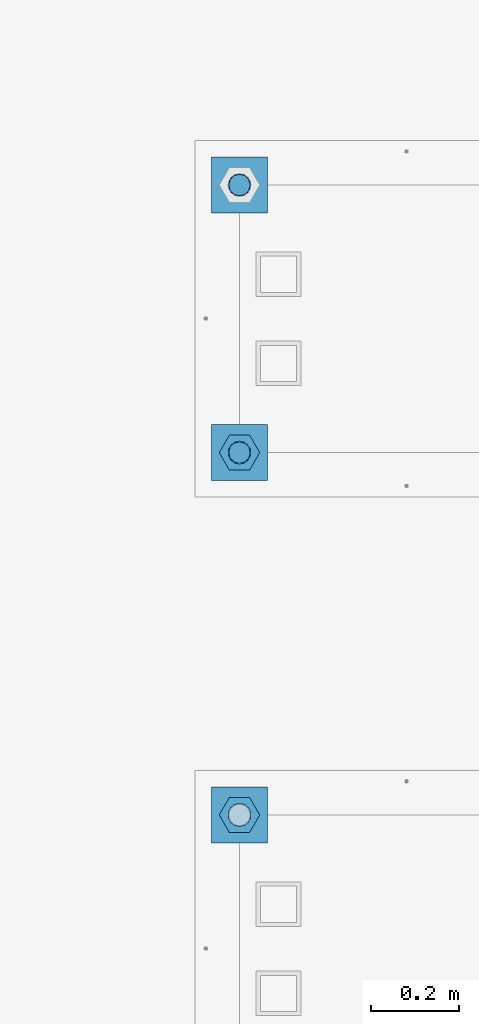
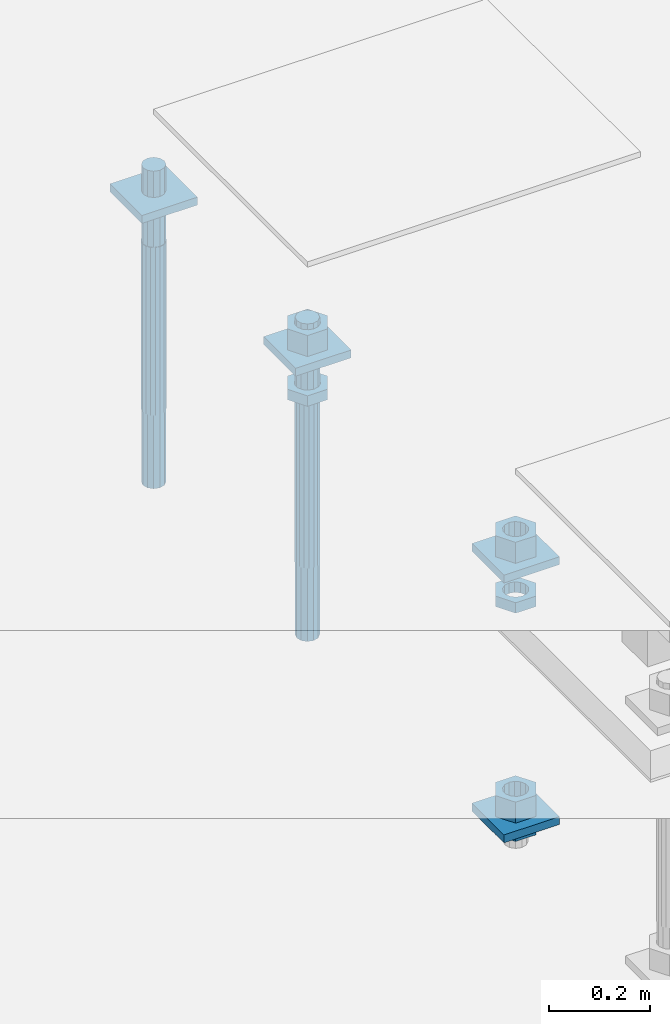
# One storey, part 2559 of 3843: 12 beams, 2 elements without a shape of their own.
"""IFC2X3 building model written with IfcOpenShell, lengths in millimetres."""

from ifc_helpers import new_model, si_unit, frame, origin_with_axes, place, context, subcontext, project, spatial, faceted_brep, material, type_object, element, aggregate, save


model = new_model("IFC2X3")

# Units and contexts
model_context = context("Model", 3, precision=1e-05, world=origin_with_axes())
body_context = subcontext(model_context, "Body", "Model", "MODEL_VIEW")
ifc_project = project(units=[si_unit("LENGTHUNIT", "METRE", prefix="MILLI"), si_unit("AREAUNIT", "SQUARE_METRE"), si_unit("VOLUMEUNIT", "CUBIC_METRE"), si_unit("MASSUNIT", "GRAM", prefix="KILO"), si_unit("TIMEUNIT", "SECOND"), si_unit("PLANEANGLEUNIT", "RADIAN"), si_unit("SOLIDANGLEUNIT", "STERADIAN"), si_unit("THERMODYNAMICTEMPERATUREUNIT", "DEGREE_CELSIUS"), si_unit("LUMINOUSINTENSITYUNIT", "LUMEN")], contexts=[model_context])

# Site, building, storey
site_placement = place(None, origin_with_axes())
site = spatial("IfcSite", under=ifc_project, at=site_placement, CompositionType="ELEMENT")
building_placement = place(site_placement, origin_with_axes())
building = spatial("IfcBuilding", under=site, at=building_placement, Name="Undefined", CompositionType="ELEMENT")
storey_placement = place(building_placement, origin_with_axes())
storey = spatial("IfcBuildingStorey", under=building, at=storey_placement, Name="Undefined", CompositionType="ELEMENT", Elevation=0.0)

# Assembly, beams
assembly_1_placement = place(storey_placement, origin_with_axes())
assembly_1 = element("IfcElementAssembly", 1, at=assembly_1_placement, inside=storey, Name="TEMPLATE", AssemblyPlace="NOTDEFINED", PredefinedType="RIGID_FRAME")
ifc_material_1 = material(Name="STEEL/A572-50")
beam_type_1 = type_object("IfcBeamType", PredefinedType="NOTDEFINED")
beam_1_placement = place(assembly_1_placement, frame((104775.0, 1892.30000152587, 29873.575), z_axis=(1.0, 0.0, 0.0), x_axis=(0.0, 1.0, 0.0)))
beam_1 = element("IfcBeam", 2, at=beam_1_placement, type_object=beam_type_1, material=ifc_material_1, Name="WASHER_PLATE", context=body_context, shape_type="Brep", body=[
    faceted_brep([(0.0, 9.52500000000146, -63.5), (0.0, 9.52500000000146, 63.5), (127.0, 9.52500000000146, 63.5), (127.0, 9.52500000000146, -63.5), (0.0, -9.52500000000146, 63.5), (127.0, -9.52500000000146, 63.5), (0.0, -9.52500000000146, -63.5), (127.0, -9.52500000000146, -63.5)], [[[0, 1, 2, 3]], [[1, 4, 5, 2]], [[4, 6, 7, 5]], [[6, 0, 3, 7]], [[5, 7, 3, 2]], [[6, 4, 1, 0]]]),
])
beam_2_placement = place(assembly_1_placement, frame((104775.0, 1892.30000152587, 29244.925), z_axis=(1.0, 0.0, 0.0), x_axis=(0.0, 1.0, 0.0)))
beam_2 = element("IfcBeam", 3, at=beam_2_placement, type_object=beam_type_1, material=ifc_material_1, Name="WASHER_PLATE", context=body_context, shape_type="Brep", body=[
    faceted_brep([(0.0, 9.52500000000146, -63.5), (0.0, 9.52500000000146, 63.5), (127.0, 9.52500000000146, 63.5), (127.0, 9.52500000000146, -63.5), (0.0, -9.52500000000146, 63.5), (127.0, -9.52500000000146, 63.5), (0.0, -9.52500000000146, -63.5), (127.0, -9.52500000000146, -63.5)], [[[0, 1, 2, 3]], [[1, 4, 5, 2]], [[4, 6, 7, 5]], [[6, 0, 3, 7]], [[5, 7, 3, 2]], [[6, 4, 1, 0]]]),
])

assembly_2_placement = place(storey_placement, origin_with_axes())
assembly_2 = element("IfcElementAssembly", 4, at=assembly_2_placement, inside=storey, Name="TEMPLATE", AssemblyPlace="NOTDEFINED", PredefinedType="RIGID_FRAME")
beam_3_placement = place(assembly_2_placement, frame((104775.0, 2717.80000152587, 29873.575), z_axis=(1.0, 0.0, 0.0), x_axis=(0.0, 1.0, 0.0)))
beam_3 = element("IfcBeam", 5, at=beam_3_placement, type_object=beam_type_1, material=ifc_material_1, Name="WASHER_PLATE", context=body_context, shape_type="Brep", body=[
    faceted_brep([(0.0, 9.52500000000146, -63.5), (0.0, 9.52500000000146, 63.5), (127.0, 9.52500000000146, 63.5), (127.0, 9.52500000000146, -63.5), (0.0, -9.52500000000146, 63.5), (127.0, -9.52500000000146, 63.5), (0.0, -9.52500000000146, -63.5), (127.0, -9.52500000000146, -63.5)], [[[0, 1, 2, 3]], [[1, 4, 5, 2]], [[4, 6, 7, 5]], [[6, 0, 3, 7]], [[5, 7, 3, 2]], [[6, 4, 1, 0]]]),
])
beam_4_placement = place(assembly_2_placement, frame((104775.0, 3327.40000152587, 29873.575), z_axis=(1.0, 0.0, 0.0), x_axis=(0.0, 1.0, 0.0)))
beam_4 = element("IfcBeam", 6, at=beam_4_placement, type_object=beam_type_1, material=ifc_material_1, Name="WASHER_PLATE", context=body_context, shape_type="Brep", body=[
    faceted_brep([(0.0, 9.52500000000146, -63.5), (0.0, 9.52500000000146, 63.5), (127.0, 9.52500000000146, 63.5), (127.0, 9.52500000000146, -63.5), (0.0, -9.52500000000146, 63.5), (127.0, -9.52500000000146, 63.5), (0.0, -9.52500000000146, -63.5), (127.0, -9.52500000000146, -63.5)], [[[0, 1, 2, 3]], [[1, 4, 5, 2]], [[4, 6, 7, 5]], [[6, 0, 3, 7]], [[5, 7, 3, 2]], [[6, 4, 1, 0]]]),
])

# Beam
ifc_material_2 = material(Name="STEEL/A36")
beam_type_2 = type_object("IfcBeamType", Name="2_HALF_NUT", PredefinedType="NOTDEFINED")
beam_5_placement = place(assembly_1_placement, frame((104775.0, 1955.80000152587, 29787.85), z_axis=(0.0, 1.0, 0.0), x_axis=(0.0, 0.0, -1.0)))
beam_5 = element("IfcBeam", 7, at=beam_5_placement, type_object=beam_type_2, material=ifc_material_2, Name="NUT", ObjectType="2_HALF_NUT", context=body_context, shape_type="Brep", body=[
    faceted_brep([(0.0, -46.0369987487793, 0.0), (0.0, -23.0184993743896, -39.869213104248), (25.4000000000015, -23.0184993743896, -39.869213104248), (25.4000000000015, -46.0369987487793, 0.0), (0.0, 23.0184993743896, -39.869213104248), (25.4000000000015, 23.0184993743896, -39.869213104248), (0.0, 46.0369987487793, 0.0), (25.4000000000015, 46.0369987487793, 0.0), (0.0, 23.0184993743896, 39.869213104248), (25.4000000000015, 23.0184993743896, 39.869213104248), (0.0, -23.0184993743896, 39.869213104248), (25.4000000000015, -23.0184993743896, 39.869213104248), (0.0, 0.0, 26.1940002441406), (0.0, 11.3650617044477, 23.5999013092805), (25.4000000000015, 11.3650617044477, 23.5999013092805), (25.4000000000015, 0.0, 26.1940002441406), (0.0, 20.4791109456419, 16.3316083006721), (25.4000000000015, 20.4791109456419, 16.3316083006721), (0.0, 25.5370200498292, 5.82867859874386), (25.4000000000015, 25.5370200498292, 5.82867859874386), (0.0, 25.5370200498292, -5.82867859874386), (25.4000000000015, 25.5370200498292, -5.82867859874386), (0.0, 20.4791109456419, -16.3316083006721), (25.4000000000015, 20.4791109456419, -16.3316083006721), (0.0, 11.3650617044477, -23.5999013092805), (25.4000000000015, 11.3650617044477, -23.5999013092805), (0.0, 0.0, -26.1940002441406), (25.4000000000015, 0.0, -26.1940002441406), (0.0, -11.3650617044477, -23.5999013092805), (25.4000000000015, -11.3650617044477, -23.5999013092805), (0.0, -20.4791109456419, -16.3316083006721), (25.4000000000015, -20.4791109456419, -16.3316083006721), (0.0, -25.5370200498292, -5.82867859874386), (25.4000000000015, -25.5370200498292, -5.82867859874386), (0.0, -25.5370200498292, 5.82867859874386), (25.4000000000015, -25.5370200498292, 5.82867859874386), (0.0, -20.4791109456419, 16.3316083006721), (25.4000000000015, -20.4791109456419, 16.3316083006721), (0.0, -11.3650617044477, 23.5999013092805), (25.4000000000015, -11.3650617044477, 23.5999013092805)], [[[0, 1, 2, 3]], [[1, 4, 5, 2]], [[4, 6, 7, 5]], [[6, 8, 9, 7]], [[8, 10, 11, 9]], [[10, 0, 3, 11]], [[12, 13, 14, 15]], [[13, 16, 17, 14]], [[16, 18, 19, 17]], [[18, 20, 21, 19]], [[20, 22, 23, 21]], [[22, 24, 25, 23]], [[24, 26, 27, 25]], [[26, 28, 29, 27]], [[28, 30, 31, 29]], [[30, 32, 33, 31]], [[32, 34, 35, 33]], [[34, 36, 37, 35]], [[36, 38, 39, 37]], [[38, 12, 15, 39]], [[5, 7, 9, 11, 3, 2], [17, 19, 21, 23, 25, 27, 29, 31, 33, 35, 37, 39, 15, 14]], [[10, 8, 6, 4, 1, 0], [38, 36, 34, 32, 30, 28, 26, 24, 22, 20, 18, 16, 13, 12]]]),
])

beam_6_placement = place(assembly_1_placement, frame((104775.0, 1955.80000152587, 29235.4), z_axis=(0.0, 1.0, 0.0), x_axis=(0.0, 0.0, -1.0)))
beam_6 = element("IfcBeam", 8, at=beam_6_placement, type_object=beam_type_2, material=ifc_material_2, Name="NUT", ObjectType="2_HALF_NUT", context=body_context, shape_type="Brep", body=[
    faceted_brep([(0.0, -46.0369987487793, 0.0), (0.0, -23.0184993743896, -39.869213104248), (25.4000000000015, -23.0184993743896, -39.869213104248), (25.4000000000015, -46.0369987487793, 0.0), (0.0, 23.0184993743896, -39.869213104248), (25.4000000000015, 23.0184993743896, -39.869213104248), (0.0, 46.0369987487793, 0.0), (25.4000000000015, 46.0369987487793, 0.0), (0.0, 23.0184993743896, 39.869213104248), (25.4000000000015, 23.0184993743896, 39.869213104248), (0.0, -23.0184993743896, 39.869213104248), (25.4000000000015, -23.0184993743896, 39.869213104248), (0.0, 0.0, 26.1940002441406), (0.0, 11.3650617044477, 23.5999013092805), (25.4000000000015, 11.3650617044477, 23.5999013092805), (25.4000000000015, 0.0, 26.1940002441406), (0.0, 20.4791109456419, 16.3316083006721), (25.4000000000015, 20.4791109456419, 16.3316083006721), (0.0, 25.5370200498292, 5.82867859874386), (25.4000000000015, 25.5370200498292, 5.82867859874386), (0.0, 25.5370200498292, -5.82867859874386), (25.4000000000015, 25.5370200498292, -5.82867859874386), (0.0, 20.4791109456419, -16.3316083006721), (25.4000000000015, 20.4791109456419, -16.3316083006721), (0.0, 11.3650617044477, -23.5999013092805), (25.4000000000015, 11.3650617044477, -23.5999013092805), (0.0, 0.0, -26.1940002441406), (25.4000000000015, 0.0, -26.1940002441406), (0.0, -11.3650617044477, -23.5999013092805), (25.4000000000015, -11.3650617044477, -23.5999013092805), (0.0, -20.4791109456419, -16.3316083006721), (25.4000000000015, -20.4791109456419, -16.3316083006721), (0.0, -25.5370200498292, -5.82867859874386), (25.4000000000015, -25.5370200498292, -5.82867859874386), (0.0, -25.5370200498292, 5.82867859874386), (25.4000000000015, -25.5370200498292, 5.82867859874386), (0.0, -20.4791109456419, 16.3316083006721), (25.4000000000015, -20.4791109456419, 16.3316083006721), (0.0, -11.3650617044477, 23.5999013092805), (25.4000000000015, -11.3650617044477, 23.5999013092805)], [[[0, 1, 2, 3]], [[1, 4, 5, 2]], [[4, 6, 7, 5]], [[6, 8, 9, 7]], [[8, 10, 11, 9]], [[10, 0, 3, 11]], [[12, 13, 14, 15]], [[13, 16, 17, 14]], [[16, 18, 19, 17]], [[18, 20, 21, 19]], [[20, 22, 23, 21]], [[22, 24, 25, 23]], [[24, 26, 27, 25]], [[26, 28, 29, 27]], [[28, 30, 31, 29]], [[30, 32, 33, 31]], [[32, 34, 35, 33]], [[34, 36, 37, 35]], [[36, 38, 39, 37]], [[38, 12, 15, 39]], [[5, 7, 9, 11, 3, 2], [17, 19, 21, 23, 25, 27, 29, 31, 33, 35, 37, 39, 15, 14]], [[10, 8, 6, 4, 1, 0], [38, 36, 34, 32, 30, 28, 26, 24, 22, 20, 18, 16, 13, 12]]]),
])

beam_7_placement = place(assembly_2_placement, frame((104775.0, 2781.30000152587, 29787.85), z_axis=(0.0, 1.0, 0.0), x_axis=(0.0, 0.0, -1.0)))
beam_7 = element("IfcBeam", 9, at=beam_7_placement, type_object=beam_type_2, material=ifc_material_2, Name="NUT", ObjectType="2_HALF_NUT", context=body_context, shape_type="Brep", body=[
    faceted_brep([(0.0, -46.0369987487793, 0.0), (0.0, -23.0184993743896, -39.869213104248), (25.4000000000015, -23.0184993743896, -39.869213104248), (25.4000000000015, -46.0369987487793, 0.0), (0.0, 23.0184993743896, -39.869213104248), (25.4000000000015, 23.0184993743896, -39.869213104248), (0.0, 46.0369987487793, 0.0), (25.4000000000015, 46.0369987487793, 0.0), (0.0, 23.0184993743896, 39.869213104248), (25.4000000000015, 23.0184993743896, 39.869213104248), (0.0, -23.0184993743896, 39.869213104248), (25.4000000000015, -23.0184993743896, 39.869213104248), (0.0, 0.0, 26.1940002441406), (0.0, 11.3650617044477, 23.5999013092805), (25.4000000000015, 11.3650617044477, 23.5999013092805), (25.4000000000015, 0.0, 26.1940002441406), (0.0, 20.4791109456419, 16.3316083006721), (25.4000000000015, 20.4791109456419, 16.3316083006721), (0.0, 25.5370200498292, 5.82867859874386), (25.4000000000015, 25.5370200498292, 5.82867859874386), (0.0, 25.5370200498292, -5.82867859874386), (25.4000000000015, 25.5370200498292, -5.82867859874386), (0.0, 20.4791109456419, -16.3316083006721), (25.4000000000015, 20.4791109456419, -16.3316083006721), (0.0, 11.3650617044477, -23.5999013092805), (25.4000000000015, 11.3650617044477, -23.5999013092805), (0.0, 0.0, -26.1940002441406), (25.4000000000015, 0.0, -26.1940002441406), (0.0, -11.3650617044477, -23.5999013092805), (25.4000000000015, -11.3650617044477, -23.5999013092805), (0.0, -20.4791109456419, -16.3316083006721), (25.4000000000015, -20.4791109456419, -16.3316083006721), (0.0, -25.5370200498292, -5.82867859874386), (25.4000000000015, -25.5370200498292, -5.82867859874386), (0.0, -25.5370200498292, 5.82867859874386), (25.4000000000015, -25.5370200498292, 5.82867859874386), (0.0, -20.4791109456419, 16.3316083006721), (25.4000000000015, -20.4791109456419, 16.3316083006721), (0.0, -11.3650617044477, 23.5999013092805), (25.4000000000015, -11.3650617044477, 23.5999013092805)], [[[0, 1, 2, 3]], [[1, 4, 5, 2]], [[4, 6, 7, 5]], [[6, 8, 9, 7]], [[8, 10, 11, 9]], [[10, 0, 3, 11]], [[12, 13, 14, 15]], [[13, 16, 17, 14]], [[16, 18, 19, 17]], [[18, 20, 21, 19]], [[20, 22, 23, 21]], [[22, 24, 25, 23]], [[24, 26, 27, 25]], [[26, 28, 29, 27]], [[28, 30, 31, 29]], [[30, 32, 33, 31]], [[32, 34, 35, 33]], [[34, 36, 37, 35]], [[36, 38, 39, 37]], [[38, 12, 15, 39]], [[5, 7, 9, 11, 3, 2], [17, 19, 21, 23, 25, 27, 29, 31, 33, 35, 37, 39, 15, 14]], [[10, 8, 6, 4, 1, 0], [38, 36, 34, 32, 30, 28, 26, 24, 22, 20, 18, 16, 13, 12]]]),
])

beam_type_3 = type_object("IfcBeamType", Name="2_HEAVY_HEX_NUT", PredefinedType="NOTDEFINED")
beam_8_placement = place(assembly_1_placement, frame((104775.0, 1955.80000152587, 29933.9), z_axis=(0.0, 1.0, 0.0), x_axis=(0.0, 0.0, -1.0)))
beam_8 = element("IfcBeam", 10, at=beam_8_placement, type_object=beam_type_3, material=ifc_material_2, Name="NUT", ObjectType="2_HEAVY_HEX_NUT", context=body_context, shape_type="Brep", body=[
    faceted_brep([(0.0, -46.0369987487793, 0.0), (0.0, -23.0184993743896, -39.869213104248), (50.7999999999993, -23.0184993743896, -39.869213104248), (50.7999999999993, -46.0369987487793, 0.0), (0.0, 23.0184993743896, -39.869213104248), (50.7999999999993, 23.0184993743896, -39.869213104248), (0.0, 46.0369987487793, 0.0), (50.7999999999993, 46.0369987487793, 0.0), (0.0, 23.0184993743896, 39.869213104248), (50.7999999999993, 23.0184993743896, 39.869213104248), (0.0, -23.0184993743896, 39.869213104248), (50.7999999999993, -23.0184993743896, 39.869213104248), (0.0, 0.0, 26.1940002441406), (0.0, 11.3650617044477, 23.5999013092805), (50.7999999999993, 11.3650617044477, 23.5999013092805), (50.7999999999993, 0.0, 26.1940002441406), (0.0, 20.4791109456419, 16.3316083006721), (50.7999999999993, 20.4791109456419, 16.3316083006721), (0.0, 25.5370200498292, 5.82867859874386), (50.7999999999993, 25.5370200498292, 5.82867859874386), (0.0, 25.5370200498292, -5.82867859874386), (50.7999999999993, 25.5370200498292, -5.82867859874386), (0.0, 20.4791109456419, -16.3316083006721), (50.7999999999993, 20.4791109456419, -16.3316083006721), (0.0, 11.3650617044477, -23.5999013092805), (50.7999999999993, 11.3650617044477, -23.5999013092805), (0.0, 0.0, -26.1940002441406), (50.7999999999993, 0.0, -26.1940002441406), (0.0, -11.3650617044477, -23.5999013092805), (50.7999999999993, -11.3650617044477, -23.5999013092805), (0.0, -20.4791109456419, -16.3316083006721), (50.7999999999993, -20.4791109456419, -16.3316083006721), (0.0, -25.5370200498292, -5.82867859874386), (50.7999999999993, -25.5370200498292, -5.82867859874386), (0.0, -25.5370200498292, 5.82867859874386), (50.7999999999993, -25.5370200498292, 5.82867859874386), (0.0, -20.4791109456419, 16.3316083006721), (50.7999999999993, -20.4791109456419, 16.3316083006721), (0.0, -11.3650617044477, 23.5999013092805), (50.7999999999993, -11.3650617044477, 23.5999013092805)], [[[0, 1, 2, 3]], [[1, 4, 5, 2]], [[4, 6, 7, 5]], [[6, 8, 9, 7]], [[8, 10, 11, 9]], [[10, 0, 3, 11]], [[12, 13, 14, 15]], [[13, 16, 17, 14]], [[16, 18, 19, 17]], [[18, 20, 21, 19]], [[20, 22, 23, 21]], [[22, 24, 25, 23]], [[24, 26, 27, 25]], [[26, 28, 29, 27]], [[28, 30, 31, 29]], [[30, 32, 33, 31]], [[32, 34, 35, 33]], [[34, 36, 37, 35]], [[36, 38, 39, 37]], [[38, 12, 15, 39]], [[5, 7, 9, 11, 3, 2], [17, 19, 21, 23, 25, 27, 29, 31, 33, 35, 37, 39, 15, 14]], [[10, 8, 6, 4, 1, 0], [38, 36, 34, 32, 30, 28, 26, 24, 22, 20, 18, 16, 13, 12]]]),
])

beam_9_placement = place(assembly_1_placement, frame((104775.0, 1955.80000152587, 29305.25), z_axis=(0.0, 1.0, 0.0), x_axis=(0.0, 0.0, -1.0)))
beam_9 = element("IfcBeam", 11, at=beam_9_placement, type_object=beam_type_3, material=ifc_material_2, Name="NUT", ObjectType="2_HEAVY_HEX_NUT", context=body_context, shape_type="Brep", body=[
    faceted_brep([(0.0, -46.0369987487793, 0.0), (0.0, -23.0184993743896, -39.869213104248), (50.7999999999993, -23.0184993743896, -39.869213104248), (50.7999999999993, -46.0369987487793, 0.0), (0.0, 23.0184993743896, -39.869213104248), (50.7999999999993, 23.0184993743896, -39.869213104248), (0.0, 46.0369987487793, 0.0), (50.7999999999993, 46.0369987487793, 0.0), (0.0, 23.0184993743896, 39.869213104248), (50.7999999999993, 23.0184993743896, 39.869213104248), (0.0, -23.0184993743896, 39.869213104248), (50.7999999999993, -23.0184993743896, 39.869213104248), (0.0, 0.0, 26.1940002441406), (0.0, 11.3650617044477, 23.5999013092805), (50.7999999999993, 11.3650617044477, 23.5999013092805), (50.7999999999993, 0.0, 26.1940002441406), (0.0, 20.4791109456419, 16.3316083006721), (50.7999999999993, 20.4791109456419, 16.3316083006721), (0.0, 25.5370200498292, 5.82867859874386), (50.7999999999993, 25.5370200498292, 5.82867859874386), (0.0, 25.5370200498292, -5.82867859874386), (50.7999999999993, 25.5370200498292, -5.82867859874386), (0.0, 20.4791109456419, -16.3316083006721), (50.7999999999993, 20.4791109456419, -16.3316083006721), (0.0, 11.3650617044477, -23.5999013092805), (50.7999999999993, 11.3650617044477, -23.5999013092805), (0.0, 0.0, -26.1940002441406), (50.7999999999993, 0.0, -26.1940002441406), (0.0, -11.3650617044477, -23.5999013092805), (50.7999999999993, -11.3650617044477, -23.5999013092805), (0.0, -20.4791109456419, -16.3316083006721), (50.7999999999993, -20.4791109456419, -16.3316083006721), (0.0, -25.5370200498292, -5.82867859874386), (50.7999999999993, -25.5370200498292, -5.82867859874386), (0.0, -25.5370200498292, 5.82867859874386), (50.7999999999993, -25.5370200498292, 5.82867859874386), (0.0, -20.4791109456419, 16.3316083006721), (50.7999999999993, -20.4791109456419, 16.3316083006721), (0.0, -11.3650617044477, 23.5999013092805), (50.7999999999993, -11.3650617044477, 23.5999013092805)], [[[0, 1, 2, 3]], [[1, 4, 5, 2]], [[4, 6, 7, 5]], [[6, 8, 9, 7]], [[8, 10, 11, 9]], [[10, 0, 3, 11]], [[12, 13, 14, 15]], [[13, 16, 17, 14]], [[16, 18, 19, 17]], [[18, 20, 21, 19]], [[20, 22, 23, 21]], [[22, 24, 25, 23]], [[24, 26, 27, 25]], [[26, 28, 29, 27]], [[28, 30, 31, 29]], [[30, 32, 33, 31]], [[32, 34, 35, 33]], [[34, 36, 37, 35]], [[36, 38, 39, 37]], [[38, 12, 15, 39]], [[5, 7, 9, 11, 3, 2], [17, 19, 21, 23, 25, 27, 29, 31, 33, 35, 37, 39, 15, 14]], [[10, 8, 6, 4, 1, 0], [38, 36, 34, 32, 30, 28, 26, 24, 22, 20, 18, 16, 13, 12]]]),
])

aggregate(assembly_1, [beam_1, beam_5, beam_8, beam_9, beam_6, beam_2])

beam_10_placement = place(assembly_2_placement, frame((104775.0, 2781.30000152587, 29933.9), z_axis=(0.0, 1.0, 0.0), x_axis=(0.0, 0.0, -1.0)))
beam_10 = element("IfcBeam", 12, at=beam_10_placement, type_object=beam_type_3, material=ifc_material_2, Name="NUT", ObjectType="2_HEAVY_HEX_NUT", context=body_context, shape_type="Brep", body=[
    faceted_brep([(0.0, -46.0369987487793, 0.0), (0.0, -23.0184993743896, -39.869213104248), (50.7999999999993, -23.0184993743896, -39.869213104248), (50.7999999999993, -46.0369987487793, 0.0), (0.0, 23.0184993743896, -39.869213104248), (50.7999999999993, 23.0184993743896, -39.869213104248), (0.0, 46.0369987487793, 0.0), (50.7999999999993, 46.0369987487793, 0.0), (0.0, 23.0184993743896, 39.869213104248), (50.7999999999993, 23.0184993743896, 39.869213104248), (0.0, -23.0184993743896, 39.869213104248), (50.7999999999993, -23.0184993743896, 39.869213104248), (0.0, 0.0, 26.1940002441406), (0.0, 11.3650617044477, 23.5999013092805), (50.7999999999993, 11.3650617044477, 23.5999013092805), (50.7999999999993, 0.0, 26.1940002441406), (0.0, 20.4791109456419, 16.3316083006721), (50.7999999999993, 20.4791109456419, 16.3316083006721), (0.0, 25.5370200498292, 5.82867859874386), (50.7999999999993, 25.5370200498292, 5.82867859874386), (0.0, 25.5370200498292, -5.82867859874386), (50.7999999999993, 25.5370200498292, -5.82867859874386), (0.0, 20.4791109456419, -16.3316083006721), (50.7999999999993, 20.4791109456419, -16.3316083006721), (0.0, 11.3650617044477, -23.5999013092805), (50.7999999999993, 11.3650617044477, -23.5999013092805), (0.0, 0.0, -26.1940002441406), (50.7999999999993, 0.0, -26.1940002441406), (0.0, -11.3650617044477, -23.5999013092805), (50.7999999999993, -11.3650617044477, -23.5999013092805), (0.0, -20.4791109456419, -16.3316083006721), (50.7999999999993, -20.4791109456419, -16.3316083006721), (0.0, -25.5370200498292, -5.82867859874386), (50.7999999999993, -25.5370200498292, -5.82867859874386), (0.0, -25.5370200498292, 5.82867859874386), (50.7999999999993, -25.5370200498292, 5.82867859874386), (0.0, -20.4791109456419, 16.3316083006721), (50.7999999999993, -20.4791109456419, 16.3316083006721), (0.0, -11.3650617044477, 23.5999013092805), (50.7999999999993, -11.3650617044477, 23.5999013092805)], [[[0, 1, 2, 3]], [[1, 4, 5, 2]], [[4, 6, 7, 5]], [[6, 8, 9, 7]], [[8, 10, 11, 9]], [[10, 0, 3, 11]], [[12, 13, 14, 15]], [[13, 16, 17, 14]], [[16, 18, 19, 17]], [[18, 20, 21, 19]], [[20, 22, 23, 21]], [[22, 24, 25, 23]], [[24, 26, 27, 25]], [[26, 28, 29, 27]], [[28, 30, 31, 29]], [[30, 32, 33, 31]], [[32, 34, 35, 33]], [[34, 36, 37, 35]], [[36, 38, 39, 37]], [[38, 12, 15, 39]], [[5, 7, 9, 11, 3, 2], [17, 19, 21, 23, 25, 27, 29, 31, 33, 35, 37, 39, 15, 14]], [[10, 8, 6, 4, 1, 0], [38, 36, 34, 32, 30, 28, 26, 24, 22, 20, 18, 16, 13, 12]]]),
])

ifc_material_3 = material()
beam_type_4 = type_object("IfcBeamType", PredefinedType="NOTDEFINED")
beam_11_placement = place(assembly_2_placement, frame((104775.000001526, 3390.89999999999, 29762.45), z_axis=(1.0, 0.0, 0.0), x_axis=(0.0, 0.0, -1.0)))
beam_11 = element("IfcBeam", 13, at=beam_11_placement, type_object=beam_type_4, material=ifc_material_3, Name="ANCHOR_ROD", context=body_context, shape_type="Brep", body=[
    faceted_brep([(0.0, -23.4665401257807, -9.72015918207035), (0.0, -17.9605122421344, -17.9605122421417), (406.399999999998, -17.9605122421344, -17.9605122421417), (406.399999999998, -23.4665401257807, -9.72015918207035), (0.0, -9.72015918207762, -23.466540125788), (406.399999999998, -9.72015918207762, -23.466540125788), (0.0, 0.0, -25.4000000000015), (406.399999999998, 0.0, -25.4000000000015), (0.0, 9.72015918207762, -23.466540125788), (406.399999999998, 9.72015918207762, -23.466540125788), (0.0, 17.9605122421344, -17.9605122421417), (406.399999999998, 17.9605122421344, -17.9605122421417), (0.0, 23.4665401257807, -9.72015918207035), (406.399999999998, 23.4665401257807, -9.72015918207035), (0.0, 25.3999996185303, 0.0), (406.399999999998, 25.3999999999942, 0.0), (0.0, 23.4665401257807, 9.72015918207035), (406.399999999998, 23.4665401257807, 9.72015918207035), (0.0, 17.9605122421344, 17.9605122421417), (406.399999999998, 17.9605122421344, 17.9605122421417), (0.0, 9.72015918207762, 23.466540125788), (406.399999999998, 9.72015918207762, 23.466540125788), (0.0, 0.0, 25.4000000000015), (406.399999999998, 0.0, 25.4000000000015), (0.0, -9.72015918207762, 23.466540125788), (406.399999999998, -9.72015918207762, 23.466540125788), (0.0, -17.9605122421344, 17.9605122421417), (406.399999999998, -17.9605122421344, 17.9605122421417), (0.0, -23.4665401257807, 9.72015918207035), (406.399999999998, -23.4665401257807, 9.72015918207035), (0.0, -25.3999996185303, 0.0), (406.399999999998, -25.3999999999942, 0.0), (584.200000000001, -12.2499999999854, -21.2176223927163), (584.200000000001, 1.45519152283669e-11, -24.5), (584.200000000001, 12.2500000000146, -21.2176223927163), (584.200000000001, 21.2176223927381, -12.25), (584.200000000001, 24.5000000000146, 0.0), (584.200000000001, 21.2176223927381, 12.25), (584.200000000001, 12.2500000000146, 21.2176223927163), (584.200000000001, 1.45519152283669e-11, 24.5), (584.200000000001, -12.2499999999854, 21.2176223927163), (584.200000000001, -21.217622392709, 12.25), (584.200000000001, -24.4999999999854, 0.0), (584.200000000001, -21.217622392709, -12.25), (406.399999999998, -24.4999999999854, 0.0), (406.399999999998, -21.217622392709, -12.25), (406.399999999998, -12.2499999999854, -21.2176223927163), (406.399999999998, 1.45519152283669e-11, -24.5), (406.399999999998, 12.2500000000146, -21.2176223927163), (406.399999999998, 21.2176223927381, -12.25), (406.399999999998, 24.5000000000146, 0.0), (406.399999999998, 21.2176223927381, 12.25), (406.399999999998, 12.2500000000146, 21.2176223927163), (406.399999999998, 1.45519152283669e-11, 24.5), (406.399999999998, -12.2499999999854, 21.2176223927163), (406.399999999998, -21.217622392709, 12.25), (0.0, 12.2500000000146, 21.2176223927163), (0.0, 1.45519152283669e-11, 24.5), (0.0, -12.2499999999854, 21.2176223927163), (0.0, -21.217622392709, 12.25), (0.0, -24.4999999999854, 0.0), (0.0, -21.217622392709, -12.25), (0.0, -12.2499999999854, -21.2176223927163), (0.0, 1.45519152283669e-11, -24.5), (0.0, 12.2500000000146, -21.2176223927163), (0.0, 21.2176223927381, -12.25), (0.0, 24.5000000000146, 0.0), (0.0, 21.2176223927381, 12.25), (-184.150000000001, -21.217622392709, 12.25), (-184.150000000001, -12.2499999999854, 21.2176223927163), (-184.150000000001, 1.45519152283669e-11, 24.5), (-184.150000000001, 12.2500000000146, 21.2176223927163), (-184.150000000001, 21.2176223927381, 12.25), (-184.150000000001, 24.5000000000146, 0.0), (-184.150000000001, 21.2176223927381, -12.25), (-184.150000000001, 12.2500000000146, -21.2176223927163), (-184.150000000001, 1.45519152283669e-11, -24.5), (-184.150000000001, -12.2499999999854, -21.2176223927163), (-184.150000000001, -21.217622392709, -12.25), (-184.150000000001, -24.4999999999854, 0.0)], [[[0, 1, 2, 3]], [[1, 4, 5, 2]], [[4, 6, 7, 5]], [[6, 8, 9, 7]], [[8, 10, 11, 9]], [[10, 12, 13, 11]], [[12, 14, 15, 13]], [[14, 16, 17, 15]], [[16, 18, 19, 17]], [[18, 20, 21, 19]], [[20, 22, 23, 21]], [[22, 24, 25, 23]], [[24, 26, 27, 25]], [[26, 28, 29, 27]], [[28, 30, 31, 29]], [[32, 33, 34, 35, 36, 37, 38, 39, 40, 41, 42, 43]], [[43, 42, 44, 45]], [[32, 43, 45, 46]], [[33, 32, 46, 47]], [[34, 33, 47, 48]], [[35, 34, 48, 49]], [[36, 35, 49, 50]], [[37, 36, 50, 51]], [[38, 37, 51, 52]], [[39, 38, 52, 53]], [[40, 39, 53, 54]], [[41, 40, 54, 55]], [[42, 41, 55, 44]], [[2, 5, 7, 9, 11, 13, 15, 17, 19, 21, 23, 25, 27, 29, 31, 3], [54, 53, 52, 51, 50, 49, 48, 47, 46, 45, 44, 55]], [[30, 0, 3, 31]], [[28, 26, 24, 22, 20, 18, 16, 14, 12, 10, 8, 6, 4, 1, 0, 30], [56, 57, 58, 59, 60, 61, 62, 63, 64, 65, 66, 67]], [[68, 69, 70, 71, 72, 73, 74, 75, 76, 77, 78, 79]], [[71, 70, 57, 56]], [[72, 71, 56, 67]], [[73, 72, 67, 66]], [[74, 73, 66, 65]], [[75, 74, 65, 64]], [[76, 75, 64, 63]], [[77, 76, 63, 62]], [[78, 77, 62, 61]], [[79, 78, 61, 60]], [[68, 79, 60, 59]], [[69, 68, 59, 58]], [[70, 69, 58, 57]]]),
])

beam_12_placement = place(assembly_2_placement, frame((104775.000001526, 2781.29999999998, 29762.45), z_axis=(1.0, 0.0, 0.0), x_axis=(0.0, 0.0, -1.0)))
beam_12 = element("IfcBeam", 14, at=beam_12_placement, type_object=beam_type_4, material=ifc_material_3, Name="ANCHOR_ROD", context=body_context, shape_type="Brep", body=[
    faceted_brep([(0.0, -23.4665401257807, -9.72015918207035), (0.0, -17.9605122421344, -17.9605122421417), (406.399999999998, -17.9605122421344, -17.9605122421417), (406.399999999998, -23.4665401257807, -9.72015918207035), (0.0, -9.72015918207762, -23.466540125788), (406.399999999998, -9.72015918207762, -23.466540125788), (0.0, 0.0, -25.4000000000015), (406.399999999998, 0.0, -25.4000000000015), (0.0, 9.72015918207762, -23.466540125788), (406.399999999998, 9.72015918207762, -23.466540125788), (0.0, 17.9605122421344, -17.9605122421417), (406.399999999998, 17.9605122421344, -17.9605122421417), (0.0, 23.4665401257807, -9.72015918207035), (406.399999999998, 23.4665401257807, -9.72015918207035), (0.0, 25.3999996185303, 0.0), (406.399999999998, 25.3999999999942, 0.0), (0.0, 23.4665401257807, 9.72015918207035), (406.399999999998, 23.4665401257807, 9.72015918207035), (0.0, 17.9605122421344, 17.9605122421417), (406.399999999998, 17.9605122421344, 17.9605122421417), (0.0, 9.72015918207762, 23.466540125788), (406.399999999998, 9.72015918207762, 23.466540125788), (0.0, 0.0, 25.4000000000015), (406.399999999998, 0.0, 25.4000000000015), (0.0, -9.72015918207762, 23.466540125788), (406.399999999998, -9.72015918207762, 23.466540125788), (0.0, -17.9605122421344, 17.9605122421417), (406.399999999998, -17.9605122421344, 17.9605122421417), (0.0, -23.4665401257807, 9.72015918207035), (406.399999999998, -23.4665401257807, 9.72015918207035), (0.0, -25.3999996185303, 0.0), (406.399999999998, -25.3999999999942, 0.0), (584.200000000001, -12.2499999999854, -21.2176223927163), (584.200000000001, 1.45519152283669e-11, -24.5), (584.200000000001, 12.2500000000146, -21.2176223927163), (584.200000000001, 21.2176223927381, -12.25), (584.200000000001, 24.5000000000146, 0.0), (584.200000000001, 21.2176223927381, 12.25), (584.200000000001, 12.2500000000146, 21.2176223927163), (584.200000000001, 1.45519152283669e-11, 24.5), (584.200000000001, -12.2499999999854, 21.2176223927163), (584.200000000001, -21.217622392709, 12.25), (584.200000000001, -24.4999999999854, 0.0), (584.200000000001, -21.217622392709, -12.25), (406.399999999998, -24.4999999999854, 0.0), (406.399999999998, -21.217622392709, -12.25), (406.399999999998, -12.2499999999854, -21.2176223927163), (406.399999999998, 1.45519152283669e-11, -24.5), (406.399999999998, 12.2500000000146, -21.2176223927163), (406.399999999998, 21.2176223927381, -12.25), (406.399999999998, 24.5000000000146, 0.0), (406.399999999998, 21.2176223927381, 12.25), (406.399999999998, 12.2500000000146, 21.2176223927163), (406.399999999998, 1.45519152283669e-11, 24.5), (406.399999999998, -12.2499999999854, 21.2176223927163), (406.399999999998, -21.217622392709, 12.25), (0.0, 12.2500000000146, 21.2176223927163), (0.0, 1.45519152283669e-11, 24.5), (0.0, -12.2499999999854, 21.2176223927163), (0.0, -21.217622392709, 12.25), (0.0, -24.4999999999854, 0.0), (0.0, -21.217622392709, -12.25), (0.0, -12.2499999999854, -21.2176223927163), (0.0, 1.45519152283669e-11, -24.5), (0.0, 12.2500000000146, -21.2176223927163), (0.0, 21.2176223927381, -12.25), (0.0, 24.5000000000146, 0.0), (0.0, 21.2176223927381, 12.25), (-184.150000000001, -21.217622392709, 12.25), (-184.150000000001, -12.2499999999854, 21.2176223927163), (-184.150000000001, 1.45519152283669e-11, 24.5), (-184.150000000001, 12.2500000000146, 21.2176223927163), (-184.150000000001, 21.2176223927381, 12.25), (-184.150000000001, 24.5000000000146, 0.0), (-184.150000000001, 21.2176223927381, -12.25), (-184.150000000001, 12.2500000000146, -21.2176223927163), (-184.150000000001, 1.45519152283669e-11, -24.5), (-184.150000000001, -12.2499999999854, -21.2176223927163), (-184.150000000001, -21.217622392709, -12.25), (-184.150000000001, -24.4999999999854, 0.0)], [[[0, 1, 2, 3]], [[1, 4, 5, 2]], [[4, 6, 7, 5]], [[6, 8, 9, 7]], [[8, 10, 11, 9]], [[10, 12, 13, 11]], [[12, 14, 15, 13]], [[14, 16, 17, 15]], [[16, 18, 19, 17]], [[18, 20, 21, 19]], [[20, 22, 23, 21]], [[22, 24, 25, 23]], [[24, 26, 27, 25]], [[26, 28, 29, 27]], [[28, 30, 31, 29]], [[32, 33, 34, 35, 36, 37, 38, 39, 40, 41, 42, 43]], [[43, 42, 44, 45]], [[32, 43, 45, 46]], [[33, 32, 46, 47]], [[34, 33, 47, 48]], [[35, 34, 48, 49]], [[36, 35, 49, 50]], [[37, 36, 50, 51]], [[38, 37, 51, 52]], [[39, 38, 52, 53]], [[40, 39, 53, 54]], [[41, 40, 54, 55]], [[42, 41, 55, 44]], [[2, 5, 7, 9, 11, 13, 15, 17, 19, 21, 23, 25, 27, 29, 31, 3], [54, 53, 52, 51, 50, 49, 48, 47, 46, 45, 44, 55]], [[30, 0, 3, 31]], [[28, 26, 24, 22, 20, 18, 16, 14, 12, 10, 8, 6, 4, 1, 0, 30], [56, 57, 58, 59, 60, 61, 62, 63, 64, 65, 66, 67]], [[68, 69, 70, 71, 72, 73, 74, 75, 76, 77, 78, 79]], [[71, 70, 57, 56]], [[72, 71, 56, 67]], [[73, 72, 67, 66]], [[74, 73, 66, 65]], [[75, 74, 65, 64]], [[76, 75, 64, 63]], [[77, 76, 63, 62]], [[78, 77, 62, 61]], [[79, 78, 61, 60]], [[68, 79, 60, 59]], [[69, 68, 59, 58]], [[70, 69, 58, 57]]]),
])

aggregate(assembly_2, [beam_11, beam_12, beam_3, beam_4, beam_7, beam_10])

save(model, "model.ifc")
